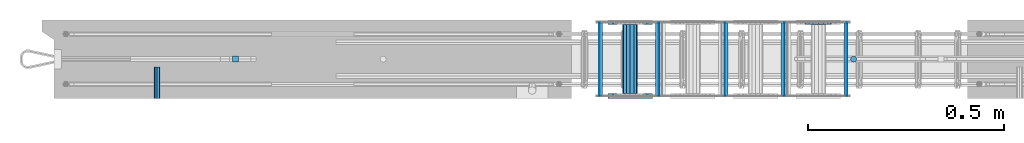
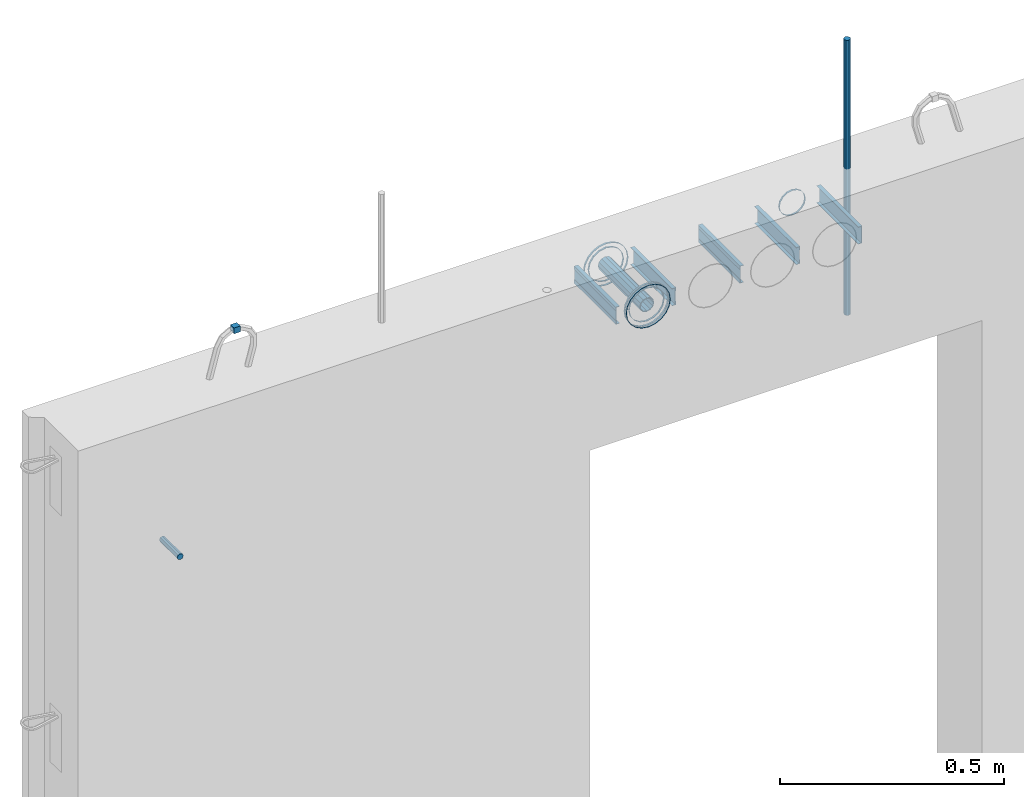
# One storey, part 4 of 11: 25 beams.
"""IFC2X3 building model written with IfcOpenShell, lengths in millimetres."""

from ifc_helpers import new_model, si_unit, frame, origin_with_axes, place, context, subcontext, project, spatial, faceted_brep, material, type_object, element, save


model = new_model("IFC2X3")

# Units and contexts
model_context = context("Model", 3, precision=1e-05, world=origin_with_axes())
body_context = subcontext(model_context, "Body", "Model", "MODEL_VIEW")
ifc_project = project(units=[si_unit("LENGTHUNIT", "METRE", prefix="MILLI"), si_unit("AREAUNIT", "SQUARE_METRE"), si_unit("VOLUMEUNIT", "CUBIC_METRE"), si_unit("MASSUNIT", "GRAM", prefix="KILO"), si_unit("TIMEUNIT", "SECOND"), si_unit("PLANEANGLEUNIT", "RADIAN"), si_unit("SOLIDANGLEUNIT", "STERADIAN"), si_unit("THERMODYNAMICTEMPERATUREUNIT", "DEGREE_CELSIUS"), si_unit("LUMINOUSINTENSITYUNIT", "LUMEN")], contexts=[model_context])

# Site, building, storey
site_placement = place(None, origin_with_axes())
site = spatial("IfcSite", under=ifc_project, at=site_placement, CompositionType="ELEMENT")
building_placement = place(site_placement, origin_with_axes())
building = spatial("IfcBuilding", under=site, at=building_placement, Name="Undefined", CompositionType="ELEMENT")
storey_placement = place(building_placement, origin_with_axes())
storey = spatial("IfcBuildingStorey", under=building, at=storey_placement, Name="Undefined", CompositionType="ELEMENT", Elevation=0.0)

# Beams
ifc_material_1 = material(Name="REBAR/A500HW")
beam_type_1 = type_object("IfcBeamType", Name="D16", PredefinedType="NOTDEFINED")
beam_1_placement = place(storey_placement, frame((2069.99001480515, -99.9999587567851, 2805.000000041), z_axis=(-1.0, 0.0, 0.0), x_axis=(0.0, 0.0, -1.0)))
element("IfcBeam", 1, at=beam_1_placement, inside=storey, type_object=beam_type_1, material=ifc_material_1, ObjectType="D16", context=body_context, shape_type="Brep", body=[
    faceted_brep([(0.0, -8.0, 0.0), (0.0, -5.65685424949238, -5.65685424949243), (750.0, -5.65685424949238, -5.65685424949243), (750.0, -8.0, 0.0), (0.0, 0.0, -8.0), (750.0, 0.0, -8.0), (0.0, 5.65685424949238, -5.65685424949243), (750.0, 5.65685424949238, -5.65685424949243), (0.0, 8.0, 0.0), (750.0, 8.0, 0.0), (0.0, 5.65685424949238, 5.65685424949243), (750.0, 5.65685424949238, 5.65685424949243), (0.0, 0.0, 8.0), (750.0, 0.0, 8.0), (0.0, -5.65685424949238, 5.65685424949243), (750.0, -5.65685424949238, 5.65685424949243)], [[[0, 1, 2, 3]], [[1, 4, 5, 2]], [[4, 6, 7, 5]], [[6, 8, 9, 7]], [[8, 10, 11, 9]], [[10, 12, 13, 11]], [[12, 14, 15, 13]], [[14, 0, 3, 15]], [[5, 7, 9, 11, 13, 15, 3, 2]], [[14, 12, 10, 8, 6, 4, 1, 0]]]),
])
ifc_material_2 = material(Name="STEEL/Steel_Undefined")
beam_2_placement = place(storey_placement, frame((293.11999948492, -199.99999941953, 2075.00000004103), z_axis=(0.0, 0.0, 1.0), x_axis=(0.0, 1.0, 0.0)))
element("IfcBeam", 2, at=beam_2_placement, inside=storey, type_object=beam_type_1, material=ifc_material_2, Name="M16", ObjectType="D16", context=body_context, shape_type="Brep", body=[
    faceted_brep([(0.0, -8.0, 0.0), (0.0, -5.65685424949238, -5.65685424949243), (79.9999858370938, -5.65685424949243, -5.65685424949243), (79.9999858370938, -8.0, 0.0), (0.0, 0.0, -8.0), (79.9999858370938, 0.0, -8.0), (0.0, 5.65685424949238, -5.65685424949243), (79.9999858370938, 5.65685424949243, -5.65685424949243), (0.0, 8.0, 0.0), (79.9999858370938, 8.0, 0.0), (0.0, 5.65685424949238, 5.65685424949243), (79.9999858370938, 5.65685424949243, 5.65685424949243), (0.0, 0.0, 8.0), (79.9999858370938, 0.0, 8.0), (0.0, -5.65685424949238, 5.65685424949243), (79.9999858370938, -5.65685424949243, 5.65685424949243)], [[[0, 1, 2, 3]], [[1, 4, 5, 2]], [[4, 6, 7, 5]], [[6, 8, 9, 7]], [[8, 10, 11, 9]], [[10, 12, 13, 11]], [[12, 14, 15, 13]], [[14, 0, 3, 15]], [[5, 7, 9, 11, 13, 15, 3, 2]], [[14, 12, 10, 8, 6, 4, 1, 0]]]),
])
beam_type_2 = type_object("IfcBeamType", PredefinedType="NOTDEFINED")
beam_3_placement = place(storey_placement, frame((1499.98457749309, -200.083170120093, 2335.01381840039), z_axis=(-1.0, 0.0, 0.0), x_axis=(0.0, 1.0, 0.0)))
element("IfcBeam", 3, at=beam_3_placement, inside=storey, type_object=beam_type_2, material=ifc_material_2, context=body_context, shape_type="Brep", body=[
    faceted_brep([(0.0, -56.0, 0.0), (0.0, -53.2591649125284, 17.3049516849972), (5.0, -53.2591649125284, 17.3049516849972), (5.0, -56.0, 0.0), (0.0, -45.3049516849969, 32.9159741283786), (5.0, -45.3049516849969, 32.9159741283786), (0.0, -32.9159741283784, 45.3049516849972), (5.0, -32.9159741283784, 45.3049516849972), (0.0, -17.3049516849969, 53.2591649125286), (5.0, -17.3049516849969, 53.2591649125286), (0.0, 0.0, 56.0), (5.0, 0.0, 56.0), (0.0, 17.3049516849969, 53.2591649125286), (5.0, 17.3049516849969, 53.2591649125286), (0.0, 32.9159741283784, 45.3049516849972), (5.0, 32.9159741283784, 45.3049516849972), (0.0, 45.3049516849969, 32.9159741283786), (5.0, 45.3049516849969, 32.9159741283786), (0.0, 53.2591649125284, 17.3049516849972), (5.0, 53.2591649125284, 17.3049516849972), (0.0, 56.0, 0.0), (5.0, 56.0, 0.0), (0.0, 53.2591649125284, -17.3049516849972), (5.0, 53.2591649125284, -17.3049516849972), (0.0, 45.3049516849969, -32.9159741283786), (5.0, 45.3049516849969, -32.9159741283786), (0.0, 32.9159741283784, -45.3049516849972), (5.0, 32.9159741283784, -45.3049516849972), (0.0, 17.3049516849969, -53.2591649125286), (5.0, 17.3049516849969, -53.2591649125286), (0.0, 0.0, -56.0), (5.0, 0.0, -56.0), (0.0, -17.3049516849969, -53.2591649125286), (5.0, -17.3049516849969, -53.2591649125286), (0.0, -32.9159741283784, -45.3049516849972), (5.0, -32.9159741283784, -45.3049516849972), (0.0, -45.3049516849969, -32.9159741283786), (5.0, -45.3049516849969, -32.9159741283786), (0.0, -53.2591649125284, -17.3049516849972), (5.0, -53.2591649125284, -17.3049516849972), (0.0, -57.0, 0.0), (0.0, -54.2102214288238, -17.613968679372), (5.0, -54.2102214288238, -17.613968679372), (5.0, -57.0, 0.0), (0.0, -46.1139686793722, -33.503759380671), (5.0, -46.1139686793722, -33.503759380671), (0.0, -33.503759380671, -46.113968679372), (5.0, -33.503759380671, -46.113968679372), (0.0, -17.6139686793722, -54.2102214288238), (5.0, -17.6139686793722, -54.2102214288238), (0.0, 0.0, -57.0), (5.0, 0.0, -57.0), (0.0, 17.6139686793722, -54.2102214288238), (5.0, 17.6139686793722, -54.2102214288238), (0.0, 33.503759380671, -46.113968679372), (5.0, 33.503759380671, -46.113968679372), (0.0, 46.1139686793722, -33.503759380671), (5.0, 46.1139686793722, -33.503759380671), (0.0, 54.2102214288238, -17.613968679372), (5.0, 54.2102214288238, -17.613968679372), (0.0, 57.0, 0.0), (5.0, 57.0, 0.0), (0.0, 54.2102214288238, 17.613968679372), (5.0, 54.2102214288238, 17.613968679372), (0.0, 46.1139686793722, 33.503759380671), (5.0, 46.1139686793722, 33.503759380671), (0.0, 33.503759380671, 46.113968679372), (5.0, 33.503759380671, 46.113968679372), (0.0, 17.6139686793722, 54.2102214288238), (5.0, 17.6139686793722, 54.2102214288238), (0.0, 0.0, 57.0), (5.0, 0.0, 57.0), (0.0, -17.6139686793722, 54.2102214288238), (5.0, -17.6139686793722, 54.2102214288238), (0.0, -33.503759380671, 46.113968679372), (5.0, -33.503759380671, 46.113968679372), (0.0, -46.1139686793722, 33.503759380671), (5.0, -46.1139686793722, 33.503759380671), (0.0, -54.2102214288238, 17.613968679372), (5.0, -54.2102214288238, 17.613968679372)], [[[0, 1, 2, 3]], [[1, 4, 5, 2]], [[4, 6, 7, 5]], [[6, 8, 9, 7]], [[8, 10, 11, 9]], [[10, 12, 13, 11]], [[12, 14, 15, 13]], [[14, 16, 17, 15]], [[16, 18, 19, 17]], [[18, 20, 21, 19]], [[20, 22, 23, 21]], [[22, 24, 25, 23]], [[24, 26, 27, 25]], [[26, 28, 29, 27]], [[28, 30, 31, 29]], [[30, 32, 33, 31]], [[32, 34, 35, 33]], [[34, 36, 37, 35]], [[36, 38, 39, 37]], [[38, 0, 3, 39]], [[40, 41, 42, 43]], [[41, 44, 45, 42]], [[44, 46, 47, 45]], [[46, 48, 49, 47]], [[48, 50, 51, 49]], [[50, 52, 53, 51]], [[52, 54, 55, 53]], [[54, 56, 57, 55]], [[56, 58, 59, 57]], [[58, 60, 61, 59]], [[60, 62, 63, 61]], [[62, 64, 65, 63]], [[64, 66, 67, 65]], [[66, 68, 69, 67]], [[68, 70, 71, 69]], [[70, 72, 73, 71]], [[72, 74, 75, 73]], [[74, 76, 77, 75]], [[76, 78, 79, 77]], [[78, 40, 43, 79]], [[45, 47, 49, 51, 53, 55, 57, 59, 61, 63, 65, 67, 69, 71, 73, 75, 77, 79, 43, 42], [5, 7, 9, 11, 13, 15, 17, 19, 21, 23, 25, 27, 29, 31, 33, 35, 37, 39, 3, 2]], [[78, 76, 74, 72, 70, 68, 66, 64, 62, 60, 58, 56, 54, 52, 50, 48, 46, 44, 41, 40], [38, 36, 34, 32, 30, 28, 26, 24, 22, 20, 18, 16, 14, 12, 10, 8, 6, 4, 1, 0]]]),
])
beam_4_placement = place(storey_placement, frame((1499.98457749309, -12.083170120093, 2335.01381840039), z_axis=(-1.0, 0.0, 0.0), x_axis=(0.0, 1.0, 0.0)))
element("IfcBeam", 4, at=beam_4_placement, inside=storey, type_object=beam_type_2, material=ifc_material_2, context=body_context, shape_type="Brep", body=[
    faceted_brep([(0.0, -56.0, 0.0), (0.0, -53.2591649125284, 17.3049516849972), (5.0, -53.2591649125284, 17.3049516849972), (5.0, -56.0, 0.0), (0.0, -45.3049516849969, 32.9159741283786), (5.0, -45.3049516849969, 32.9159741283786), (0.0, -32.9159741283784, 45.3049516849972), (5.0, -32.9159741283784, 45.3049516849972), (0.0, -17.3049516849969, 53.2591649125286), (5.0, -17.3049516849969, 53.2591649125286), (0.0, 0.0, 56.0), (5.0, 0.0, 56.0), (0.0, 17.3049516849969, 53.2591649125286), (5.0, 17.3049516849969, 53.2591649125286), (0.0, 32.9159741283784, 45.3049516849972), (5.0, 32.9159741283784, 45.3049516849972), (0.0, 45.3049516849969, 32.9159741283786), (5.0, 45.3049516849969, 32.9159741283786), (0.0, 53.2591649125284, 17.3049516849972), (5.0, 53.2591649125284, 17.3049516849972), (0.0, 56.0, 0.0), (5.0, 56.0, 0.0), (0.0, 53.2591649125284, -17.3049516849972), (5.0, 53.2591649125284, -17.3049516849972), (0.0, 45.3049516849969, -32.9159741283786), (5.0, 45.3049516849969, -32.9159741283786), (0.0, 32.9159741283784, -45.3049516849972), (5.0, 32.9159741283784, -45.3049516849972), (0.0, 17.3049516849969, -53.2591649125286), (5.0, 17.3049516849969, -53.2591649125286), (0.0, 0.0, -56.0), (5.0, 0.0, -56.0), (0.0, -17.3049516849969, -53.2591649125286), (5.0, -17.3049516849969, -53.2591649125286), (0.0, -32.9159741283784, -45.3049516849972), (5.0, -32.9159741283784, -45.3049516849972), (0.0, -45.3049516849969, -32.9159741283786), (5.0, -45.3049516849969, -32.9159741283786), (0.0, -53.2591649125284, -17.3049516849972), (5.0, -53.2591649125284, -17.3049516849972), (0.0, -57.0, 0.0), (0.0, -54.2102214288238, -17.613968679372), (5.0, -54.2102214288238, -17.613968679372), (5.0, -57.0, 0.0), (0.0, -46.1139686793722, -33.503759380671), (5.0, -46.1139686793722, -33.503759380671), (0.0, -33.503759380671, -46.113968679372), (5.0, -33.503759380671, -46.113968679372), (0.0, -17.6139686793722, -54.2102214288238), (5.0, -17.6139686793722, -54.2102214288238), (0.0, 0.0, -57.0), (5.0, 0.0, -57.0), (0.0, 17.6139686793722, -54.2102214288238), (5.0, 17.6139686793722, -54.2102214288238), (0.0, 33.503759380671, -46.113968679372), (5.0, 33.503759380671, -46.113968679372), (0.0, 46.1139686793722, -33.503759380671), (5.0, 46.1139686793722, -33.503759380671), (0.0, 54.2102214288238, -17.613968679372), (5.0, 54.2102214288238, -17.613968679372), (0.0, 57.0, 0.0), (5.0, 57.0, 0.0), (0.0, 54.2102214288238, 17.613968679372), (5.0, 54.2102214288238, 17.613968679372), (0.0, 46.1139686793722, 33.503759380671), (5.0, 46.1139686793722, 33.503759380671), (0.0, 33.503759380671, 46.113968679372), (5.0, 33.503759380671, 46.113968679372), (0.0, 17.6139686793722, 54.2102214288238), (5.0, 17.6139686793722, 54.2102214288238), (0.0, 0.0, 57.0), (5.0, 0.0, 57.0), (0.0, -17.6139686793722, 54.2102214288238), (5.0, -17.6139686793722, 54.2102214288238), (0.0, -33.503759380671, 46.113968679372), (5.0, -33.503759380671, 46.113968679372), (0.0, -46.1139686793722, 33.503759380671), (5.0, -46.1139686793722, 33.503759380671), (0.0, -54.2102214288238, 17.613968679372), (5.0, -54.2102214288238, 17.613968679372)], [[[0, 1, 2, 3]], [[1, 4, 5, 2]], [[4, 6, 7, 5]], [[6, 8, 9, 7]], [[8, 10, 11, 9]], [[10, 12, 13, 11]], [[12, 14, 15, 13]], [[14, 16, 17, 15]], [[16, 18, 19, 17]], [[18, 20, 21, 19]], [[20, 22, 23, 21]], [[22, 24, 25, 23]], [[24, 26, 27, 25]], [[26, 28, 29, 27]], [[28, 30, 31, 29]], [[30, 32, 33, 31]], [[32, 34, 35, 33]], [[34, 36, 37, 35]], [[36, 38, 39, 37]], [[38, 0, 3, 39]], [[40, 41, 42, 43]], [[41, 44, 45, 42]], [[44, 46, 47, 45]], [[46, 48, 49, 47]], [[48, 50, 51, 49]], [[50, 52, 53, 51]], [[52, 54, 55, 53]], [[54, 56, 57, 55]], [[56, 58, 59, 57]], [[58, 60, 61, 59]], [[60, 62, 63, 61]], [[62, 64, 65, 63]], [[64, 66, 67, 65]], [[66, 68, 69, 67]], [[68, 70, 71, 69]], [[70, 72, 73, 71]], [[72, 74, 75, 73]], [[74, 76, 77, 75]], [[76, 78, 79, 77]], [[78, 40, 43, 79]], [[45, 47, 49, 51, 53, 55, 57, 59, 61, 63, 65, 67, 69, 71, 73, 75, 77, 79, 43, 42], [5, 7, 9, 11, 13, 15, 17, 19, 21, 23, 25, 27, 29, 31, 33, 35, 37, 39, 3, 2]], [[78, 76, 74, 72, 70, 68, 66, 64, 62, 60, 58, 56, 54, 52, 50, 48, 46, 44, 41, 40], [38, 36, 34, 32, 30, 28, 26, 24, 22, 20, 18, 16, 14, 12, 10, 8, 6, 4, 1, 0]]]),
])
beam_5_placement = place(storey_placement, frame((1499.98457749309, -188.083170120093, 2335.01381840039), z_axis=(-1.0, 0.0, 0.0), x_axis=(0.0, -1.0, 0.0)))
element("IfcBeam", 5, at=beam_5_placement, inside=storey, type_object=beam_type_2, material=ifc_material_2, context=body_context, shape_type="Brep", body=[
    faceted_brep([(0.0, -56.0, 0.0), (0.0, -53.2591649125284, 17.3049516849972), (5.0, -53.2591649125284, 17.3049516849972), (5.0, -56.0, 0.0), (0.0, -45.3049516849969, 32.9159741283786), (5.0, -45.3049516849969, 32.9159741283786), (0.0, -32.9159741283784, 45.3049516849972), (5.0, -32.9159741283784, 45.3049516849972), (0.0, -17.3049516849969, 53.2591649125286), (5.0, -17.3049516849969, 53.2591649125286), (0.0, 0.0, 56.0), (5.0, 0.0, 56.0), (0.0, 17.3049516849969, 53.2591649125286), (5.0, 17.3049516849969, 53.2591649125286), (0.0, 32.9159741283784, 45.3049516849972), (5.0, 32.9159741283784, 45.3049516849972), (0.0, 45.3049516849969, 32.9159741283786), (5.0, 45.3049516849969, 32.9159741283786), (0.0, 53.2591649125284, 17.3049516849972), (5.0, 53.2591649125284, 17.3049516849972), (0.0, 56.0, 0.0), (5.0, 56.0, 0.0), (0.0, 53.2591649125284, -17.3049516849972), (5.0, 53.2591649125284, -17.3049516849972), (0.0, 45.3049516849969, -32.9159741283786), (5.0, 45.3049516849969, -32.9159741283786), (0.0, 32.9159741283784, -45.3049516849972), (5.0, 32.9159741283784, -45.3049516849972), (0.0, 17.3049516849969, -53.2591649125286), (5.0, 17.3049516849969, -53.2591649125286), (0.0, 0.0, -56.0), (5.0, 0.0, -56.0), (0.0, -17.3049516849969, -53.2591649125286), (5.0, -17.3049516849969, -53.2591649125286), (0.0, -32.9159741283784, -45.3049516849972), (5.0, -32.9159741283784, -45.3049516849972), (0.0, -45.3049516849969, -32.9159741283786), (5.0, -45.3049516849969, -32.9159741283786), (0.0, -53.2591649125284, -17.3049516849972), (5.0, -53.2591649125284, -17.3049516849972), (0.0, -57.0, 0.0), (0.0, -54.2102214288238, -17.613968679372), (5.0, -54.2102214288238, -17.613968679372), (5.0, -57.0, 0.0), (0.0, -46.1139686793722, -33.503759380671), (5.0, -46.1139686793722, -33.503759380671), (0.0, -33.503759380671, -46.113968679372), (5.0, -33.503759380671, -46.113968679372), (0.0, -17.6139686793722, -54.2102214288238), (5.0, -17.6139686793722, -54.2102214288238), (0.0, 0.0, -57.0), (5.0, 0.0, -57.0), (0.0, 17.6139686793722, -54.2102214288238), (5.0, 17.6139686793722, -54.2102214288238), (0.0, 33.503759380671, -46.113968679372), (5.0, 33.503759380671, -46.113968679372), (0.0, 46.1139686793722, -33.503759380671), (5.0, 46.1139686793722, -33.503759380671), (0.0, 54.2102214288238, -17.613968679372), (5.0, 54.2102214288238, -17.613968679372), (0.0, 57.0, 0.0), (5.0, 57.0, 0.0), (0.0, 54.2102214288238, 17.613968679372), (5.0, 54.2102214288238, 17.613968679372), (0.0, 46.1139686793722, 33.503759380671), (5.0, 46.1139686793722, 33.503759380671), (0.0, 33.503759380671, 46.113968679372), (5.0, 33.503759380671, 46.113968679372), (0.0, 17.6139686793722, 54.2102214288238), (5.0, 17.6139686793722, 54.2102214288238), (0.0, 0.0, 57.0), (5.0, 0.0, 57.0), (0.0, -17.6139686793722, 54.2102214288238), (5.0, -17.6139686793722, 54.2102214288238), (0.0, -33.503759380671, 46.113968679372), (5.0, -33.503759380671, 46.113968679372), (0.0, -46.1139686793722, 33.503759380671), (5.0, -46.1139686793722, 33.503759380671), (0.0, -54.2102214288238, 17.613968679372), (5.0, -54.2102214288238, 17.613968679372)], [[[0, 1, 2, 3]], [[1, 4, 5, 2]], [[4, 6, 7, 5]], [[6, 8, 9, 7]], [[8, 10, 11, 9]], [[10, 12, 13, 11]], [[12, 14, 15, 13]], [[14, 16, 17, 15]], [[16, 18, 19, 17]], [[18, 20, 21, 19]], [[20, 22, 23, 21]], [[22, 24, 25, 23]], [[24, 26, 27, 25]], [[26, 28, 29, 27]], [[28, 30, 31, 29]], [[30, 32, 33, 31]], [[32, 34, 35, 33]], [[34, 36, 37, 35]], [[36, 38, 39, 37]], [[38, 0, 3, 39]], [[40, 41, 42, 43]], [[41, 44, 45, 42]], [[44, 46, 47, 45]], [[46, 48, 49, 47]], [[48, 50, 51, 49]], [[50, 52, 53, 51]], [[52, 54, 55, 53]], [[54, 56, 57, 55]], [[56, 58, 59, 57]], [[58, 60, 61, 59]], [[60, 62, 63, 61]], [[62, 64, 65, 63]], [[64, 66, 67, 65]], [[66, 68, 69, 67]], [[68, 70, 71, 69]], [[70, 72, 73, 71]], [[72, 74, 75, 73]], [[74, 76, 77, 75]], [[76, 78, 79, 77]], [[78, 40, 43, 79]], [[45, 47, 49, 51, 53, 55, 57, 59, 61, 63, 65, 67, 69, 71, 73, 75, 77, 79, 43, 42], [5, 7, 9, 11, 13, 15, 17, 19, 21, 23, 25, 27, 29, 31, 33, 35, 37, 39, 3, 2]], [[78, 76, 74, 72, 70, 68, 66, 64, 62, 60, 58, 56, 54, 52, 50, 48, 46, 44, 41, 40], [38, 36, 34, 32, 30, 28, 26, 24, 22, 20, 18, 16, 14, 12, 10, 8, 6, 4, 1, 0]]]),
])
beam_type_3 = type_object("IfcBeamType", PredefinedType="NOTDEFINED")
beam_6_placement = place(storey_placement, frame((1979.98457749309, -12.083170120093, 2335.01381840039), z_axis=(-1.0, 0.0, 0.0), x_axis=(0.0, 1.0, 0.0)))
element("IfcBeam", 6, at=beam_6_placement, inside=storey, type_object=beam_type_3, material=ifc_material_2, context=body_context, shape_type="Brep", body=[
    faceted_brep([(0.0, -33.0, 0.0), (0.0, -30.4880245728723, 12.6285532680479), (5.0, -30.4880245728723, 12.6285532680479), (5.0, -33.0, 0.0), (0.0, -23.3345237791559, 23.3345237791561), (5.0, -23.3345237791559, 23.3345237791561), (0.0, -12.6285532680481, 30.4880245728725), (5.0, -12.6285532680481, 30.4880245728725), (0.0, 0.0, 33.0), (5.0, 0.0, 33.0), (0.0, 12.6285532680481, 30.4880245728725), (5.0, 12.6285532680481, 30.4880245728725), (0.0, 23.3345237791559, 23.3345237791561), (5.0, 23.3345237791559, 23.3345237791561), (0.0, 30.4880245728723, 12.6285532680479), (5.0, 30.4880245728723, 12.6285532680479), (0.0, 33.0, 0.0), (5.0, 33.0, 0.0), (0.0, 30.4880245728723, -12.6285532680479), (5.0, 30.4880245728723, -12.6285532680479), (0.0, 23.3345237791559, -23.3345237791561), (5.0, 23.3345237791559, -23.3345237791561), (0.0, 12.6285532680481, -30.4880245728725), (5.0, 12.6285532680481, -30.4880245728725), (0.0, 0.0, -33.0), (5.0, 0.0, -33.0), (0.0, -12.6285532680481, -30.4880245728725), (5.0, -12.6285532680481, -30.4880245728725), (0.0, -23.3345237791559, -23.3345237791561), (5.0, -23.3345237791559, -23.3345237791561), (0.0, -30.4880245728723, -12.6285532680479), (5.0, -30.4880245728723, -12.6285532680479), (0.0, -34.0, 0.0), (0.0, -31.4119041053837, -13.0112367004131), (5.0, -31.4119041053837, -13.0112367004131), (5.0, -34.0, 0.0), (0.0, -24.0416305603426, -24.0416305603426), (5.0, -24.0416305603426, -24.0416305603426), (0.0, -13.0112367004131, -31.4119041053837), (5.0, -13.0112367004131, -31.4119041053837), (0.0, 0.0, -34.0), (5.0, 0.0, -34.0), (0.0, 13.0112367004131, -31.4119041053837), (5.0, 13.0112367004131, -31.4119041053837), (0.0, 24.0416305603426, -24.0416305603426), (5.0, 24.0416305603426, -24.0416305603426), (0.0, 31.4119041053837, -13.0112367004131), (5.0, 31.4119041053837, -13.0112367004131), (0.0, 34.0, 0.0), (5.0, 34.0, 0.0), (0.0, 31.4119041053837, 13.0112367004131), (5.0, 31.4119041053837, 13.0112367004131), (0.0, 24.0416305603426, 24.0416305603426), (5.0, 24.0416305603426, 24.0416305603426), (0.0, 13.0112367004131, 31.4119041053837), (5.0, 13.0112367004131, 31.4119041053837), (0.0, 0.0, 34.0), (5.0, 0.0, 34.0), (0.0, -13.0112367004131, 31.4119041053837), (5.0, -13.0112367004131, 31.4119041053837), (0.0, -24.0416305603426, 24.0416305603426), (5.0, -24.0416305603426, 24.0416305603426), (0.0, -31.4119041053837, 13.0112367004131), (5.0, -31.4119041053837, 13.0112367004131)], [[[0, 1, 2, 3]], [[1, 4, 5, 2]], [[4, 6, 7, 5]], [[6, 8, 9, 7]], [[8, 10, 11, 9]], [[10, 12, 13, 11]], [[12, 14, 15, 13]], [[14, 16, 17, 15]], [[16, 18, 19, 17]], [[18, 20, 21, 19]], [[20, 22, 23, 21]], [[22, 24, 25, 23]], [[24, 26, 27, 25]], [[26, 28, 29, 27]], [[28, 30, 31, 29]], [[30, 0, 3, 31]], [[32, 33, 34, 35]], [[33, 36, 37, 34]], [[36, 38, 39, 37]], [[38, 40, 41, 39]], [[40, 42, 43, 41]], [[42, 44, 45, 43]], [[44, 46, 47, 45]], [[46, 48, 49, 47]], [[48, 50, 51, 49]], [[50, 52, 53, 51]], [[52, 54, 55, 53]], [[54, 56, 57, 55]], [[56, 58, 59, 57]], [[58, 60, 61, 59]], [[60, 62, 63, 61]], [[62, 32, 35, 63]], [[37, 39, 41, 43, 45, 47, 49, 51, 53, 55, 57, 59, 61, 63, 35, 34], [5, 7, 9, 11, 13, 15, 17, 19, 21, 23, 25, 27, 29, 31, 3, 2]], [[62, 60, 58, 56, 54, 52, 50, 48, 46, 44, 42, 40, 38, 36, 33, 32], [30, 28, 26, 24, 22, 20, 18, 16, 14, 12, 10, 8, 6, 4, 1, 0]]]),
])
beam_type_4 = type_object("IfcBeamType", PredefinedType="NOTDEFINED")
beam_7_placement = place(storey_placement, frame((1499.98457749309, -12.083170120093, 2335.01381840039), z_axis=(-1.0, 0.0, 0.0), x_axis=(0.0, 1.0, 0.0)))
element("IfcBeam", 7, at=beam_7_placement, inside=storey, type_object=beam_type_4, material=ifc_material_2, context=body_context, shape_type="Brep", body=[
    faceted_brep([(0.0, -44.5, 0.0), (0.0, -41.1126391967523, 17.0294127402465), (5.0, -41.1126391967523, 17.0294127402465), (5.0, -44.5, 0.0), (0.0, -31.4662517628012, 31.4662517628014), (5.0, -31.4662517628012, 31.4662517628014), (0.0, -17.0294127402467, 41.1126391967523), (5.0, -17.0294127402467, 41.1126391967523), (0.0, 0.0, 44.5), (5.0, 0.0, 44.5), (0.0, 17.0294127402467, 41.1126391967523), (5.0, 17.0294127402467, 41.1126391967523), (0.0, 31.4662517628012, 31.4662517628014), (5.0, 31.4662517628012, 31.4662517628014), (0.0, 41.1126391967523, 17.0294127402465), (5.0, 41.1126391967523, 17.0294127402465), (0.0, 44.5, 0.0), (5.0, 44.5, 0.0), (0.0, 41.1126391967523, -17.0294127402465), (5.0, 41.1126391967523, -17.0294127402465), (0.0, 31.4662517628012, -31.4662517628014), (5.0, 31.4662517628012, -31.4662517628014), (0.0, 17.0294127402467, -41.1126391967523), (5.0, 17.0294127402467, -41.1126391967523), (0.0, 0.0, -44.5), (5.0, 0.0, -44.5), (0.0, -17.0294127402467, -41.1126391967523), (5.0, -17.0294127402467, -41.1126391967523), (0.0, -31.4662517628012, -31.4662517628014), (5.0, -31.4662517628012, -31.4662517628014), (0.0, -41.1126391967523, -17.0294127402465), (5.0, -41.1126391967523, -17.0294127402465), (0.0, -45.5, 0.0), (0.0, -42.0365187292637, -17.4120961726117), (5.0, -42.0365187292637, -17.4120961726117), (5.0, -45.5, 0.0), (0.0, -32.1733585439879, -32.1733585439879), (5.0, -32.1733585439879, -32.1733585439879), (0.0, -17.4120961726117, -42.0365187292634), (5.0, -17.4120961726117, -42.0365187292634), (0.0, 0.0, -45.5), (5.0, 0.0, -45.5), (0.0, 17.4120961726117, -42.0365187292634), (5.0, 17.4120961726117, -42.0365187292634), (0.0, 32.1733585439879, -32.1733585439879), (5.0, 32.1733585439879, -32.1733585439879), (0.0, 42.0365187292637, -17.4120961726117), (5.0, 42.0365187292637, -17.4120961726117), (0.0, 45.5, 0.0), (5.0, 45.5, 0.0), (0.0, 42.0365187292637, 17.4120961726117), (5.0, 42.0365187292637, 17.4120961726117), (0.0, 32.1733585439879, 32.1733585439879), (5.0, 32.1733585439879, 32.1733585439879), (0.0, 17.4120961726117, 42.0365187292634), (5.0, 17.4120961726117, 42.0365187292634), (0.0, 0.0, 45.5), (5.0, 0.0, 45.5), (0.0, -17.4120961726117, 42.0365187292634), (5.0, -17.4120961726117, 42.0365187292634), (0.0, -32.1733585439879, 32.1733585439879), (5.0, -32.1733585439879, 32.1733585439879), (0.0, -42.0365187292637, 17.4120961726117), (5.0, -42.0365187292637, 17.4120961726117)], [[[0, 1, 2, 3]], [[1, 4, 5, 2]], [[4, 6, 7, 5]], [[6, 8, 9, 7]], [[8, 10, 11, 9]], [[10, 12, 13, 11]], [[12, 14, 15, 13]], [[14, 16, 17, 15]], [[16, 18, 19, 17]], [[18, 20, 21, 19]], [[20, 22, 23, 21]], [[22, 24, 25, 23]], [[24, 26, 27, 25]], [[26, 28, 29, 27]], [[28, 30, 31, 29]], [[30, 0, 3, 31]], [[32, 33, 34, 35]], [[33, 36, 37, 34]], [[36, 38, 39, 37]], [[38, 40, 41, 39]], [[40, 42, 43, 41]], [[42, 44, 45, 43]], [[44, 46, 47, 45]], [[46, 48, 49, 47]], [[48, 50, 51, 49]], [[50, 52, 53, 51]], [[52, 54, 55, 53]], [[54, 56, 57, 55]], [[56, 58, 59, 57]], [[58, 60, 61, 59]], [[60, 62, 63, 61]], [[62, 32, 35, 63]], [[37, 39, 41, 43, 45, 47, 49, 51, 53, 55, 57, 59, 61, 63, 35, 34], [5, 7, 9, 11, 13, 15, 17, 19, 21, 23, 25, 27, 29, 31, 3, 2]], [[62, 60, 58, 56, 54, 52, 50, 48, 46, 44, 42, 40, 38, 36, 33, 32], [30, 28, 26, 24, 22, 20, 18, 16, 14, 12, 10, 8, 6, 4, 1, 0]]]),
])
beam_8_placement = place(storey_placement, frame((1499.98457749309, -188.083170120093, 2335.01381840039), z_axis=(-1.0, 0.0, 0.0), x_axis=(0.0, -1.0, 0.0)))
element("IfcBeam", 8, at=beam_8_placement, inside=storey, type_object=beam_type_4, material=ifc_material_2, context=body_context, shape_type="Brep", body=[
    faceted_brep([(0.0, -44.5, 0.0), (0.0, -41.1126391967523, 17.0294127402465), (5.0, -41.1126391967523, 17.0294127402465), (5.0, -44.5, 0.0), (0.0, -31.4662517628012, 31.4662517628014), (5.0, -31.4662517628012, 31.4662517628014), (0.0, -17.0294127402467, 41.1126391967523), (5.0, -17.0294127402467, 41.1126391967523), (0.0, 0.0, 44.5), (5.0, 0.0, 44.5), (0.0, 17.0294127402467, 41.1126391967523), (5.0, 17.0294127402467, 41.1126391967523), (0.0, 31.4662517628012, 31.4662517628014), (5.0, 31.4662517628012, 31.4662517628014), (0.0, 41.1126391967523, 17.0294127402465), (5.0, 41.1126391967523, 17.0294127402465), (0.0, 44.5, 0.0), (5.0, 44.5, 0.0), (0.0, 41.1126391967523, -17.0294127402465), (5.0, 41.1126391967523, -17.0294127402465), (0.0, 31.4662517628012, -31.4662517628014), (5.0, 31.4662517628012, -31.4662517628014), (0.0, 17.0294127402467, -41.1126391967523), (5.0, 17.0294127402467, -41.1126391967523), (0.0, 0.0, -44.5), (5.0, 0.0, -44.5), (0.0, -17.0294127402467, -41.1126391967523), (5.0, -17.0294127402467, -41.1126391967523), (0.0, -31.4662517628012, -31.4662517628014), (5.0, -31.4662517628012, -31.4662517628014), (0.0, -41.1126391967523, -17.0294127402465), (5.0, -41.1126391967523, -17.0294127402465), (0.0, -45.5, 0.0), (0.0, -42.0365187292637, -17.4120961726117), (5.0, -42.0365187292637, -17.4120961726117), (5.0, -45.5, 0.0), (0.0, -32.1733585439879, -32.1733585439879), (5.0, -32.1733585439879, -32.1733585439879), (0.0, -17.4120961726117, -42.0365187292634), (5.0, -17.4120961726117, -42.0365187292634), (0.0, 0.0, -45.5), (5.0, 0.0, -45.5), (0.0, 17.4120961726117, -42.0365187292634), (5.0, 17.4120961726117, -42.0365187292634), (0.0, 32.1733585439879, -32.1733585439879), (5.0, 32.1733585439879, -32.1733585439879), (0.0, 42.0365187292637, -17.4120961726117), (5.0, 42.0365187292637, -17.4120961726117), (0.0, 45.5, 0.0), (5.0, 45.5, 0.0), (0.0, 42.0365187292637, 17.4120961726117), (5.0, 42.0365187292637, 17.4120961726117), (0.0, 32.1733585439879, 32.1733585439879), (5.0, 32.1733585439879, 32.1733585439879), (0.0, 17.4120961726117, 42.0365187292634), (5.0, 17.4120961726117, 42.0365187292634), (0.0, 0.0, 45.5), (5.0, 0.0, 45.5), (0.0, -17.4120961726117, 42.0365187292634), (5.0, -17.4120961726117, 42.0365187292634), (0.0, -32.1733585439879, 32.1733585439879), (5.0, -32.1733585439879, 32.1733585439879), (0.0, -42.0365187292637, 17.4120961726117), (5.0, -42.0365187292637, 17.4120961726117)], [[[0, 1, 2, 3]], [[1, 4, 5, 2]], [[4, 6, 7, 5]], [[6, 8, 9, 7]], [[8, 10, 11, 9]], [[10, 12, 13, 11]], [[12, 14, 15, 13]], [[14, 16, 17, 15]], [[16, 18, 19, 17]], [[18, 20, 21, 19]], [[20, 22, 23, 21]], [[22, 24, 25, 23]], [[24, 26, 27, 25]], [[26, 28, 29, 27]], [[28, 30, 31, 29]], [[30, 0, 3, 31]], [[32, 33, 34, 35]], [[33, 36, 37, 34]], [[36, 38, 39, 37]], [[38, 40, 41, 39]], [[40, 42, 43, 41]], [[42, 44, 45, 43]], [[44, 46, 47, 45]], [[46, 48, 49, 47]], [[48, 50, 51, 49]], [[50, 52, 53, 51]], [[52, 54, 55, 53]], [[54, 56, 57, 55]], [[56, 58, 59, 57]], [[58, 60, 61, 59]], [[60, 62, 63, 61]], [[62, 32, 35, 63]], [[37, 39, 41, 43, 45, 47, 49, 51, 53, 55, 57, 59, 61, 63, 35, 34], [5, 7, 9, 11, 13, 15, 17, 19, 21, 23, 25, 27, 29, 31, 3, 2]], [[62, 60, 58, 56, 54, 52, 50, 48, 46, 44, 42, 40, 38, 36, 33, 32], [30, 28, 26, 24, 22, 20, 18, 16, 14, 12, 10, 8, 6, 4, 1, 0]]]),
])
beam_type_5 = type_object("IfcBeamType", PredefinedType="NOTDEFINED")
beam_9_placement = place(storey_placement, frame((1499.98457749309, -193.083170120093, 2335.01381840039), z_axis=(-1.0, 0.0, 0.0), x_axis=(0.0, 1.0, 0.0)))
element("IfcBeam", 9, at=beam_9_placement, inside=storey, type_object=beam_type_5, material=ifc_material_2, context=body_context, shape_type="Brep", body=[
    faceted_brep([(0.0, -17.0, 0.0), (0.0, -14.7224318643352, 8.5), (186.0, -14.7224318643352, 8.5), (186.0, -17.0, 0.0), (0.0, -8.5, 14.7224318643355), (186.0, -8.5, 14.7224318643355), (0.0, 0.0, 17.0), (186.0, 0.0, 17.0), (0.0, 8.5, 14.7224318643355), (186.0, 8.5, 14.7224318643355), (0.0, 14.7224318643352, 8.5), (186.0, 14.7224318643352, 8.5), (0.0, 17.0, 0.0), (186.0, 17.0, 0.0), (0.0, 14.7224318643352, -8.5), (186.0, 14.7224318643352, -8.5), (0.0, 8.5, -14.7224318643355), (186.0, 8.5, -14.7224318643355), (0.0, 0.0, -17.0), (186.0, 0.0, -17.0), (0.0, -8.5, -14.7224318643355), (186.0, -8.5, -14.7224318643355), (0.0, -14.7224318643352, -8.5), (186.0, -14.7224318643352, -8.5), (0.0, -19.0, 0.0), (0.0, -16.4544826719043, -9.5), (186.0, -16.4544826719043, -9.5), (186.0, -19.0, 0.0), (0.0, -9.5, -16.4544826719043), (186.0, -9.5, -16.4544826719043), (0.0, 0.0, -19.0), (186.0, 0.0, -19.0), (0.0, 9.5, -16.4544826719043), (186.0, 9.5, -16.4544826719043), (0.0, 16.4544826719043, -9.5), (186.0, 16.4544826719043, -9.5), (0.0, 19.0, 0.0), (186.0, 19.0, 0.0), (0.0, 16.4544826719043, 9.5), (186.0, 16.4544826719043, 9.5), (0.0, 9.5, 16.4544826719043), (186.0, 9.5, 16.4544826719043), (0.0, 0.0, 19.0), (186.0, 0.0, 19.0), (0.0, -9.5, 16.4544826719043), (186.0, -9.5, 16.4544826719043), (0.0, -16.4544826719043, 9.5), (186.0, -16.4544826719043, 9.5)], [[[0, 1, 2, 3]], [[1, 4, 5, 2]], [[4, 6, 7, 5]], [[6, 8, 9, 7]], [[8, 10, 11, 9]], [[10, 12, 13, 11]], [[12, 14, 15, 13]], [[14, 16, 17, 15]], [[16, 18, 19, 17]], [[18, 20, 21, 19]], [[20, 22, 23, 21]], [[22, 0, 3, 23]], [[24, 25, 26, 27]], [[25, 28, 29, 26]], [[28, 30, 31, 29]], [[30, 32, 33, 31]], [[32, 34, 35, 33]], [[34, 36, 37, 35]], [[36, 38, 39, 37]], [[38, 40, 41, 39]], [[40, 42, 43, 41]], [[42, 44, 45, 43]], [[44, 46, 47, 45]], [[46, 24, 27, 47]], [[29, 31, 33, 35, 37, 39, 41, 43, 45, 47, 27, 26], [5, 7, 9, 11, 13, 15, 17, 19, 21, 23, 3, 2]], [[46, 44, 42, 40, 38, 36, 34, 32, 30, 28, 25, 24], [22, 20, 18, 16, 14, 12, 10, 8, 6, 4, 1, 0]]]),
])
beam_type_6 = type_object("IfcBeamType", PredefinedType="NOTDEFINED")
for number, where, z_axis, x_axis in (
    (10, (2049.98457749309, -7.08317012009296, 2351.0138184004), (-1.0, 0.0, 0.0), (0.0, -1.0, 0.0)),
    (11, (2049.98457749309, -193.083170120093, 2314.0138184004), (-1.0, 0.0, 0.0), (0.0, 1.0, 0.0)),
    (12, (1744.98457749309, -7.08317012009296, 2351.0138184004), (0.0, 0.0, -1.0), (0.0, -1.0, 0.0)),
    (13, (1744.98457749309, -193.083170120093, 2314.0138184004), (0.0, 0.0, 1.0), (0.0, 1.0, 0.0)),
    (14, (1889.98457749309, -7.08317012009296, 2351.0138184004), (-1.0, 0.0, 0.0), (0.0, -1.0, 0.0)),
    (15, (1889.98457749309, -193.083170120093, 2314.0138184004), (-1.0, 0.0, 0.0), (0.0, 1.0, 0.0)),
    (16, (1424.98457749309, -7.08317012009302, 2351.0138184004), (0.0, 0.0, -1.0), (0.0, -1.0, 0.0)),
    (17, (1424.98457749309, -193.083170120093, 2314.0138184004), (0.0, 0.0, 1.0), (0.0, 1.0, 0.0)),
    (18, (1569.98457749309, -7.08317012009302, 2351.0138184004), (-1.0, 0.0, 0.0), (0.0, -1.0, 0.0)),
    (19, (1569.98457749309, -193.083170120093, 2314.0138184004), (-1.0, 0.0, 0.0), (0.0, 1.0, 0.0)),
):
    element("IfcBeam", number, at=place(storey_placement, frame(where, z_axis=z_axis, x_axis=x_axis)), inside=storey, type_object=beam_type_6, material=ifc_material_2, context=body_context, shape_type="Brep", body=[
        faceted_brep([(0.0, 5.0, -5.0), (0.0, 5.0, 5.0), (186.0, 5.0, 5.0), (186.0, 5.0, -5.0), (0.0, 4.0, 5.0), (186.0, 4.0, 5.0), (0.0, 4.0, -4.0), (186.0, 4.0, -4.0), (0.0, -5.0, -4.0), (186.0, -5.0, -4.0), (0.0, -5.0, -5.0), (186.0, -5.0, -5.0)], [[[0, 1, 2, 3]], [[1, 4, 5, 2]], [[4, 6, 7, 5]], [[6, 8, 9, 7]], [[8, 10, 11, 9]], [[10, 0, 3, 11]], [[5, 7, 9, 11, 3, 2]], [[10, 8, 6, 4, 1, 0]]]),
    ])
beam_type_7 = type_object("IfcBeamType", Name="1X45", PredefinedType="NOTDEFINED")
for number, where, z_axis, x_axis in (
    (20, (2053.48457749309, -193.083170120093, 2332.5138184004), (-1.0, 0.0, 0.0), (0.0, 1.0, 0.0)),
    (21, (1741.48457749309, -193.083170120093, 2332.5138184004), (-1.0, 0.0, 0.0), (0.0, 1.0, 0.0)),
    (22, (1893.48457749309, -193.083170120093, 2332.5138184004), (-1.0, 0.0, 0.0), (0.0, 1.0, 0.0)),
    (23, (1421.48457749309, -193.083170120093, 2332.5138184004), (-1.0, 0.0, 0.0), (0.0, 1.0, 0.0)),
    (24, (1573.48457749309, -193.083170120093, 2332.5138184004), (-1.0, 0.0, 0.0), (0.0, 1.0, 0.0)),
):
    element("IfcBeam", number, at=place(storey_placement, frame(where, z_axis=z_axis, x_axis=x_axis)), inside=storey, type_object=beam_type_7, material=ifc_material_2, ObjectType="1X45", context=body_context, shape_type="Brep", body=[
        faceted_brep([(0.0, 22.5, -0.5), (0.0, 22.5, 0.5), (186.0, 22.5, 0.5), (186.0, 22.5, -0.5), (0.0, -22.5, 0.5), (186.0, -22.5, 0.5), (0.0, -22.5, -0.5), (186.0, -22.5, -0.5)], [[[0, 1, 2, 3]], [[1, 4, 5, 2]], [[4, 6, 7, 5]], [[6, 0, 3, 7]], [[5, 7, 3, 2]], [[6, 4, 1, 0]]]),
    ])
ifc_material_3 = material()
beam_type_8 = type_object("IfcBeamType", PredefinedType="NOTDEFINED")
beam_10_placement = place(storey_placement, frame((485.127761185232, -99.5664404567494, 2567.00000004103), z_axis=(0.0, 0.0, 1.0), x_axis=(1.0, 0.0, 0.0)))
element("IfcBeam", 25, at=beam_10_placement, inside=storey, type_object=beam_type_8, material=ifc_material_3, context=body_context, shape_type="Brep", body=[
    faceted_brep([(0.0, 8.0, -8.0), (0.0, 8.0, 8.0), (16.0, 8.0, 8.0), (16.0, 8.0, -8.0), (0.0, -8.0, 8.0), (16.0, -8.0, 8.0), (0.0, -8.0, -8.0), (16.0, -8.0, -8.0)], [[[0, 1, 2, 3]], [[1, 4, 5, 2]], [[4, 6, 7, 5]], [[6, 0, 3, 7]], [[5, 7, 3, 2]], [[6, 4, 1, 0]]]),
])

save(model, "model.ifc")
